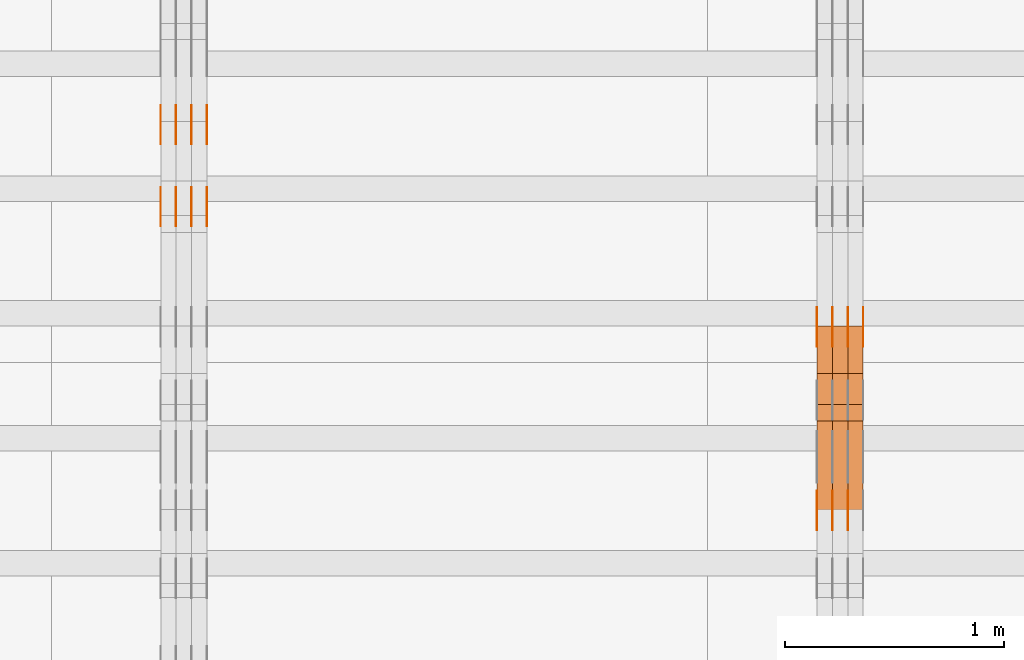
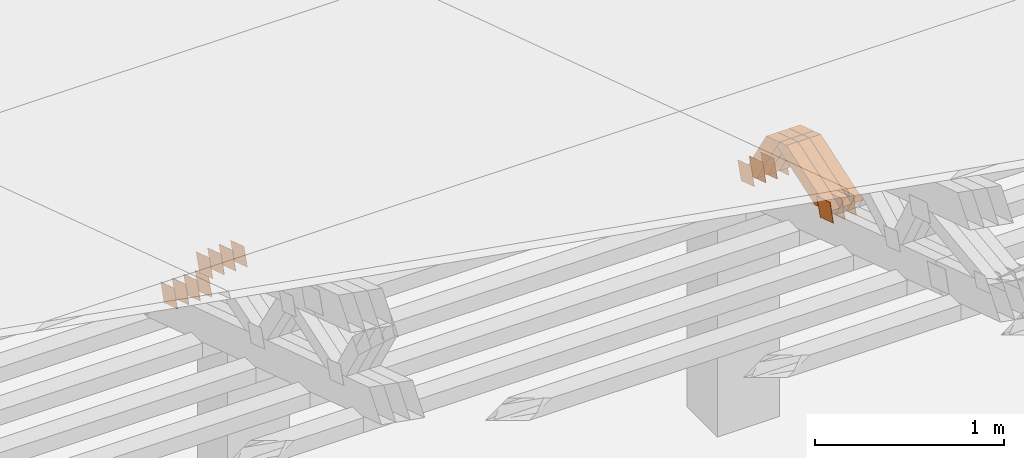
# One storey, part 197 of 385: 28 proxies.
"""IFC2X3 building model written with IfcOpenShell, lengths in millimetres."""

import ifcopenshell
import ifcopenshell.guid

model = None  # the IFC model being written
_history = None  # IfcOwnerHistory: only IFC2X3 demands one
_inside = {}  # id of a spatial element -> (the spatial element, [elements in it])
_under = {}  # id of a project, library or spatial element -> (it, [spatial elements below it])
_declared = {}  # id of a project -> (the project, [libraries it declares])
_typed = {}  # id of a type object -> (the type object, [elements of that type])
_made_of = {}  # id of a material, layer set ... -> (it, [elements and type objects made of it])


def new_model(schema):
    """Start an empty IFC model of exactly this schema.

    Asked for "IFC4X3", IfcOpenShell would pick the latest addendum, in which some entities
    have other attributes; the version numbers below select the first issue.
    IFC2X3 requires an IfcOwnerHistory on every rooted entity: one is made here for all.
    """
    global model, _history
    if schema == "IFC4X3":
        model = ifcopenshell.file(schema_version=(4, 3, 0, 0))
    else:
        model = ifcopenshell.file(schema=schema)
    _inside.clear()
    _under.clear()
    _declared.clear()
    _typed.clear()
    _made_of.clear()
    _history = None
    if model.schema == "IFC2X3":
        org = make("IfcOrganization", Name="unknown")
        user = make(
            "IfcPersonAndOrganization",
            ThePerson=make("IfcPerson", FamilyName="unknown"),
            TheOrganization=org,
        )
        app = make(
            "IfcApplication",
            ApplicationDeveloper=org,
            Version="unknown",
            ApplicationFullName="unknown",
            ApplicationIdentifier="unknown",
        )
        _history = make(
            "IfcOwnerHistory",
            OwningUser=user,
            OwningApplication=app,
            ChangeAction="ADDED",
            CreationDate=0,
        )
    return model


def make(cls, **values):
    """One entity of the class cls with the attributes given. An attribute that is None is left unset."""
    return model.create_entity(
        cls, **{name: value for name, value in values.items() if value is not None}
    )


def entity(cls, *values):
    """Any entity or typed value of the class cls, its attributes in the order of the schema. None: left unset."""
    e = model.create_entity(cls)
    for i, value in enumerate(values):
        if value is not None:
            e[i] = value
    return e


def rooted(cls, **values):
    """An entity with a GlobalId (a new one), such as an element, a storey or a relation."""
    return make(cls, GlobalId=ifcopenshell.guid.new(), OwnerHistory=_history, **values)


def si_unit(unit_type, name, prefix=None):
    """IfcSIUnit, for example si_unit("LENGTHUNIT", "METRE", prefix="MILLI")."""
    return make("IfcSIUnit", UnitType=unit_type, Prefix=prefix, Name=name)


def converted_unit(unit_type, name, factor, base, dimensions=None, offset=None):
    """IfcConversionBasedUnit, such as the inch: factor (a typed value) times the base unit."""
    return make(
        "IfcConversionBasedUnit"
        if offset is None
        else "IfcConversionBasedUnitWithOffset",
        ConversionOffset=offset,
        Dimensions=None
        if dimensions is None
        else entity("IfcDimensionalExponents", *dimensions),
        UnitType=unit_type,
        Name=name,
        ConversionFactor=make(
            "IfcMeasureWithUnit", ValueComponent=factor, UnitComponent=base
        ),
    )


def derived_unit(unit_type, elements):
    """IfcDerivedUnit: a product of units, each with its exponent."""
    return make(
        "IfcDerivedUnit",
        Elements=[
            make("IfcDerivedUnitElement", Unit=unit, Exponent=power)
            for unit, power in elements
        ],
        UnitType=unit_type,
    )


def assignment(units):
    """IfcUnitAssignment: the units of a project."""
    return None if units is None else make("IfcUnitAssignment", Units=units)


def point(xyz):
    """IfcCartesianPoint."""
    return None if xyz is None else make("IfcCartesianPoint", Coordinates=xyz)


def direction(xyz):
    """IfcDirection."""
    return None if xyz is None else make("IfcDirection", DirectionRatios=xyz)


def frame(location, z_axis=None, x_axis=None):
    """IfcAxis2Placement3D, a coordinate frame: its origin and axes. An axis left out is left unset."""
    return make(
        "IfcAxis2Placement3D",
        Location=point(location),
        Axis=direction(z_axis),
        RefDirection=direction(x_axis),
    )


def origin():
    """The frame at (0, 0, 0) with its axes left unset."""
    return frame((0.0, 0.0, 0.0))


def place(relative_to, where):
    """IfcLocalPlacement: puts the frame where relative to a parent placement (None: the world)."""
    return make(
        "IfcLocalPlacement", PlacementRelTo=relative_to, RelativePlacement=where
    )


def context(
    kind, dimensions, precision=None, world=None, true_north=None, identifier=None
):
    """IfcGeometricRepresentationContext, for example the 3D "Model" context."""
    return make(
        "IfcGeometricRepresentationContext",
        ContextIdentifier=identifier,
        ContextType=kind,
        CoordinateSpaceDimension=dimensions,
        Precision=precision,
        WorldCoordinateSystem=world,
        TrueNorth=true_north,
    )


def subcontext(parent, identifier, kind, view, scale=None):
    """IfcGeometricRepresentationSubContext, for example "Body" below "Model"."""
    return make(
        "IfcGeometricRepresentationSubContext",
        ContextIdentifier=identifier,
        ContextType=kind,
        ParentContext=parent,
        TargetScale=scale,
        TargetView=view,
    )


def project(units=None, contexts=None):
    """IfcProject with its units and contexts."""
    return rooted(
        "IfcProject",
        Name="project",
        RepresentationContexts=contexts,
        UnitsInContext=assignment(units),
    )


def spatial(cls, under=None, at=None, **own):
    """A site, building, storey or space (cls), placed at a placement, below another one or the project."""
    s = rooted(cls, ObjectPlacement=at, **own)
    if under is not None:
        _under.setdefault(under.id(), (under, []))[1].append(s)
    return s


def polyline(points):
    """IfcPolyline through the points."""
    return make("IfcPolyline", Points=[point(p) for p in points])


def outline(outer, holes=None, kind="AREA"):
    """IfcArbitraryClosedProfileDef: a profile drawn as a closed curve; with holes, ...WithVoids."""
    if holes is None:
        return make("IfcArbitraryClosedProfileDef", ProfileType=kind, OuterCurve=outer)
    return make(
        "IfcArbitraryProfileDefWithVoids",
        ProfileType=kind,
        OuterCurve=outer,
        InnerCurves=holes,
    )


def extrude(swept, where, along, depth):
    """IfcExtrudedAreaSolid: the profile swept, set in the frame where, extruded along a direction by depth."""
    return make(
        "IfcExtrudedAreaSolid",
        SweptArea=swept,
        Position=where,
        ExtrudedDirection=direction(along),
        Depth=depth,
    )


def shape(context_of_items, identifier, shape_type, items):
    """IfcShapeRepresentation: the items that make up one representation, for example the "Body"."""
    return make(
        "IfcShapeRepresentation",
        ContextOfItems=context_of_items,
        RepresentationIdentifier=identifier,
        RepresentationType=shape_type,
        Items=items,
    )


def source(mapping_origin, context_of_items, identifier, shape_type, items):
    """IfcRepresentationMap: a shape defined once, which mapped items show again and again."""
    return make(
        "IfcRepresentationMap",
        MappingOrigin=mapping_origin,
        MappedRepresentation=shape(context_of_items, identifier, shape_type, items),
    )


def transform(
    local_origin,
    x_axis=None,
    y_axis=None,
    z_axis=None,
    scale=None,
    scale2=None,
    scale3=None,
    uniform=True,
):
    """IfcCartesianTransformationOperator3D, or its non-uniform kind. x_axis, y_axis, z_axis: its Axis1, 2, 3."""
    if uniform:
        return make(
            "IfcCartesianTransformationOperator3D",
            Axis1=direction(x_axis),
            Axis2=direction(y_axis),
            LocalOrigin=point(local_origin),
            Scale=scale,
            Axis3=direction(z_axis),
        )
    return make(
        "IfcCartesianTransformationOperator3DnonUniform",
        Axis1=direction(x_axis),
        Axis2=direction(y_axis),
        LocalOrigin=point(local_origin),
        Scale=scale,
        Axis3=direction(z_axis),
        Scale2=scale2,
        Scale3=scale3,
    )


def mapped(mapping_source, mapping_target):
    """IfcMappedItem: shows the shape of a source again, moved by a transform."""
    return make(
        "IfcMappedItem", MappingSource=mapping_source, MappingTarget=mapping_target
    )


def material(Name=None, Category=None):
    """IfcMaterial."""
    return make("IfcMaterial", Name=Name, Category=Category)


def made_of(thing, what):
    """Note that an element or type object is made of a material, layer set ...; save() writes the relation."""
    if what is not None:
        _made_of.setdefault(what.id(), (what, []))[1].append(thing)
    return thing


def type_object(cls, material=None, **own):
    """A type object (cls), such as IfcWallType, which elements share."""
    return made_of(rooted(cls, **own), material)


def type_shapes(of_type, sources):
    """Give a type object the sources (RepresentationMaps) that its elements show as mapped items."""
    of_type.RepresentationMaps = sources


def element(
    cls,
    number,
    at=None,
    inside=None,
    cuts=None,
    type_object=None,
    material=None,
    context=None,
    identifier="Body",
    shape_type=None,
    held_by="IfcProductDefinitionShape",
    body=None,
    shapes=None,
    **own,
):
    """One element of the class cls, such as IfcWall. Its Tag is "e" and its number.

    at: its placement. inside: the storey or other place that contains it. cuts: it is an
    opening in that element (IfcRelVoidsElement). A single representation is given by context,
    identifier, shape_type and body (its items); several are given by shapes. held_by: the class
    of the entity that holds the representations. save() writes the other relations.
    """
    e = rooted(cls, Tag="e%d" % number, ObjectPlacement=at, **own)
    if body is not None:
        shapes = [shape(context, identifier, shape_type, body)]
    if shapes is not None:
        e.Representation = make(held_by, Representations=shapes)
    if inside is not None:
        _inside.setdefault(inside.id(), (inside, []))[1].append(e)
    if cuts is not None:
        rooted(
            "IfcRelVoidsElement", RelatingBuildingElement=cuts, RelatedOpeningElement=e
        )
    if type_object is not None:
        _typed.setdefault(type_object.id(), (type_object, []))[1].append(e)
    return made_of(e, material)


def aggregate(whole, parts):
    """IfcRelAggregates: a whole, such as a stair, and the parts it consists of."""
    return rooted("IfcRelAggregates", RelatingObject=whole, RelatedObjects=parts)


def save(model, path):
    """Write the relations noted so far, then the file.

    IfcRelAggregates (storeys below a building ...), IfcRelContainedInSpatialStructure (elements
    in a storey), IfcRelDefinesByType, IfcRelAssociatesMaterial and IfcRelDeclares: one each for
    every whole, place, type object, material and project.
    """
    for whole, parts in _under.values():
        aggregate(whole, parts)
    for where, things in _inside.values():
        rooted(
            "IfcRelContainedInSpatialStructure",
            RelatedElements=things,
            RelatingStructure=where,
        )
    for kind, things in _typed.values():
        rooted("IfcRelDefinesByType", RelatedObjects=things, RelatingType=kind)
    for what, things in _made_of.values():
        rooted("IfcRelAssociatesMaterial", RelatedObjects=things, RelatingMaterial=what)
    for by, libraries in _declared.values():
        rooted("IfcRelDeclares", RelatingContext=by, RelatedDefinitions=libraries)
    model.write(path)


model = new_model("IFC2X3")

# Units and contexts
model_context = context("Model", 3, precision=0.01, world=origin(), true_north=direction((6.12303176911189e-17, 1.0)))
body_context = subcontext(model_context, "Body", "Model", "MODEL_VIEW")
ifc_project = project(units=[si_unit("LENGTHUNIT", "METRE", prefix="MILLI"), si_unit("AREAUNIT", "SQUARE_METRE"), si_unit("VOLUMEUNIT", "CUBIC_METRE"), converted_unit("PLANEANGLEUNIT", "DEGREE", entity("IfcRatioMeasure", 0.0174532925199433), si_unit("PLANEANGLEUNIT", "RADIAN"), dimensions=[0, 0, 0, 0, 0, 0, 0]), si_unit("MASSUNIT", "GRAM", prefix="KILO"), derived_unit("MASSDENSITYUNIT", [(si_unit("MASSUNIT", "GRAM", prefix="KILO"), 1), (si_unit("LENGTHUNIT", "METRE"), -3)]), si_unit("TIMEUNIT", "SECOND"), si_unit("FREQUENCYUNIT", "HERTZ"), si_unit("THERMODYNAMICTEMPERATUREUNIT", "DEGREE_CELSIUS"), derived_unit("THERMALTRANSMITTANCEUNIT", [(si_unit("MASSUNIT", "GRAM", prefix="KILO"), 1), (si_unit("THERMODYNAMICTEMPERATUREUNIT", "KELVIN"), -1), (si_unit("TIMEUNIT", "SECOND"), -3)]), derived_unit("VOLUMETRICFLOWRATEUNIT", [(si_unit("LENGTHUNIT", "METRE"), 3), (si_unit("TIMEUNIT", "SECOND"), -1)]), si_unit("ELECTRICCURRENTUNIT", "AMPERE"), si_unit("ELECTRICVOLTAGEUNIT", "VOLT"), si_unit("POWERUNIT", "WATT"), si_unit("FORCEUNIT", "NEWTON", prefix="KILO"), si_unit("ILLUMINANCEUNIT", "LUX"), si_unit("LUMINOUSFLUXUNIT", "LUMEN"), si_unit("LUMINOUSINTENSITYUNIT", "CANDELA"), derived_unit("USERDEFINED", [(si_unit("MASSUNIT", "GRAM", prefix="KILO"), -1), (si_unit("LENGTHUNIT", "METRE"), -2), (si_unit("TIMEUNIT", "SECOND"), 3), (si_unit("LUMINOUSFLUXUNIT", "LUMEN"), 1)]), derived_unit("LINEARVELOCITYUNIT", [(si_unit("LENGTHUNIT", "METRE"), 1), (si_unit("TIMEUNIT", "SECOND"), -1)]), si_unit("PRESSUREUNIT", "PASCAL"), derived_unit("USERDEFINED", [(si_unit("LENGTHUNIT", "METRE"), -2), (si_unit("MASSUNIT", "GRAM", prefix="KILO"), 1), (si_unit("TIMEUNIT", "SECOND"), -2)])], contexts=[model_context])

# Site, building, storey
site_placement = place(None, origin())
site = spatial("IfcSite", under=ifc_project, at=site_placement, CompositionType="ELEMENT")
building_placement = place(site_placement, origin())
building = spatial("IfcBuilding", under=site, at=building_placement, CompositionType="ELEMENT")
storey_placement = place(building_placement, origin())
storey = spatial("IfcBuildingStorey", under=building, at=storey_placement, Name="Default", CompositionType="ELEMENT", Elevation=0.0)

# Proxies
ifc_material_1 = material(Name="IfcSurfaceStyle #203896")
building_element_proxy_type_1 = type_object("IfcBuildingElementProxyType", PredefinedType="NOTDEFINED", material=ifc_material_1)
shared_shape_1 = source(origin(), body_context, "Body", "SweptSolid", [
    extrude(outline(polyline([(-74.9998605591118, -59.9999264677598), (74.9998754286171, -59.9999264677598), (74.9998605591136, 59.9999264677598), (-74.9998754286189, 59.9999264677598), (-74.9998605591118, -59.9999264677598)])), frame((75.0000347664736, 60.0000016373434, 0.0), z_axis=(0.0, 0.0, 1.0), x_axis=(-1.0, 0.0, 0.0)), (0.0, 0.0, 1.0), 1.3),
])
type_shapes(building_element_proxy_type_1, [shared_shape_1])
proxy_1_placement = place(building_placement, frame((15316.3, 20117.0890328685, 2105.40814929196), z_axis=(-1.0, 0.0, 0.0), x_axis=(0.0, -0.951056516295124, 0.309016994375039)))
element("IfcBuildingElementProxy", 1, at=proxy_1_placement, inside=storey, type_object=building_element_proxy_type_1, material=ifc_material_1, context=body_context, shape_type="MappedRepresentation", body=[
    mapped(shared_shape_1, transform((0.0, 0.0, 0.0), scale=1.0)),
])
ifc_material_2 = material(Name="IfcSurfaceStyle #203839")
building_element_proxy_type_2 = type_object("IfcBuildingElementProxyType", PredefinedType="NOTDEFINED", material=ifc_material_2)
shared_shape_2 = source(origin(), body_context, "Body", "SweptSolid", [
    extrude(outline(polyline([(-74.9998605591118, -59.9999264677598), (74.9998754286171, -59.9999264677598), (74.9998605591136, 59.9999264677598), (-74.9998754286189, 59.9999264677598), (-74.9998605591118, -59.9999264677598)])), frame((75.0000347664736, 60.0000016373434, 0.0), z_axis=(0.0, 0.0, 1.0), x_axis=(-1.0, 0.0, 0.0)), (0.0, 0.0, 1.0), 1.29999999999999),
])
type_shapes(building_element_proxy_type_2, [shared_shape_2])
proxy_2_placement = place(building_placement, frame((15245.0, 20117.0890328685, 2105.40814929196), z_axis=(-1.0, 0.0, 0.0), x_axis=(0.0, -0.951056516295124, 0.309016994375039)))
element("IfcBuildingElementProxy", 2, at=proxy_2_placement, inside=storey, type_object=building_element_proxy_type_2, material=ifc_material_2, context=body_context, shape_type="MappedRepresentation", body=[
    mapped(shared_shape_2, transform((0.0, 0.0, 0.0), scale=1.0)),
])
ifc_material_3 = material(Name="IfcSurfaceStyle #203782")
building_element_proxy_type_3 = type_object("IfcBuildingElementProxyType", PredefinedType="NOTDEFINED", material=ifc_material_3)
shared_shape_3 = source(origin(), body_context, "Body", "SweptSolid", [
    extrude(outline(polyline([(-74.9998605591118, -59.9999264677598), (74.9998754286171, -59.9999264677598), (74.9998605591136, 59.9999264677598), (-74.9998754286189, 59.9999264677598), (-74.9998605591118, -59.9999264677598)])), frame((75.0000347664736, 60.0000016373434, 0.0), z_axis=(0.0, 0.0, 1.0), x_axis=(-1.0, 0.0, 0.0)), (0.0, 0.0, 1.0), 1.29999999999999),
])
type_shapes(building_element_proxy_type_3, [shared_shape_3])
proxy_3_placement = place(building_placement, frame((15246.3, 20117.0890328685, 2105.40814929196), z_axis=(-1.0, 0.0, 0.0), x_axis=(0.0, -0.951056516295124, 0.309016994375039)))
element("IfcBuildingElementProxy", 3, at=proxy_3_placement, inside=storey, type_object=building_element_proxy_type_3, material=ifc_material_3, context=body_context, shape_type="MappedRepresentation", body=[
    mapped(shared_shape_3, transform((0.0, 0.0, 0.0), scale=1.0)),
])
ifc_material_4 = material(Name="IfcSurfaceStyle #203725")
building_element_proxy_type_4 = type_object("IfcBuildingElementProxyType", PredefinedType="NOTDEFINED", material=ifc_material_4)
shared_shape_4 = source(origin(), body_context, "Body", "SweptSolid", [
    extrude(outline(polyline([(-74.9998605591118, -59.9999264677598), (74.9998754286171, -59.9999264677598), (74.9998605591136, 59.9999264677598), (-74.9998754286189, 59.9999264677598), (-74.9998605591118, -59.9999264677598)])), frame((75.0000347664736, 60.0000016373434, 0.0), z_axis=(0.0, 0.0, 1.0), x_axis=(-1.0, 0.0, 0.0)), (0.0, 0.0, 1.0), 1.29999999999999),
])
type_shapes(building_element_proxy_type_4, [shared_shape_4])
proxy_4_placement = place(building_placement, frame((15175.0, 20117.0890328685, 2105.40814929196), z_axis=(-1.0, 0.0, 0.0), x_axis=(0.0, -0.951056516295124, 0.309016994375039)))
element("IfcBuildingElementProxy", 4, at=proxy_4_placement, inside=storey, type_object=building_element_proxy_type_4, material=ifc_material_4, context=body_context, shape_type="MappedRepresentation", body=[
    mapped(shared_shape_4, transform((0.0, 0.0, 0.0), scale=1.0)),
])
ifc_material_5 = material(Name="IfcSurfaceStyle #203668")
building_element_proxy_type_5 = type_object("IfcBuildingElementProxyType", PredefinedType="NOTDEFINED", material=ifc_material_5)
shared_shape_5 = source(origin(), body_context, "Body", "SweptSolid", [
    extrude(outline(polyline([(-74.9998794200132, -59.999984515643), (74.9998565677174, -59.999984515643), (74.9998794200123, 59.999984515643), (-74.9998565677165, 59.999984515643), (-74.9998794200132, -59.999984515643)])), frame((75.0002235343086, 60.0000596852268, 0.0), z_axis=(0.0, 0.0, 1.0), x_axis=(-1.0, 0.0, 0.0)), (0.0, 0.0, 1.0), 1.3),
])
type_shapes(building_element_proxy_type_5, [shared_shape_5])
proxy_5_placement = place(building_placement, frame((15386.3, 20956.2317725846, 1832.75404405346), z_axis=(-1.0, 0.0, 0.0), x_axis=(0.0, -0.951056516295124, 0.309016994375039)))
element("IfcBuildingElementProxy", 5, at=proxy_5_placement, inside=storey, type_object=building_element_proxy_type_5, material=ifc_material_5, context=body_context, shape_type="MappedRepresentation", body=[
    mapped(shared_shape_5, transform((0.0, 0.0, 0.0), scale=1.0)),
])
ifc_material_6 = material(Name="IfcSurfaceStyle #203611")
building_element_proxy_type_6 = type_object("IfcBuildingElementProxyType", PredefinedType="NOTDEFINED", material=ifc_material_6)
shared_shape_6 = source(origin(), body_context, "Body", "SweptSolid", [
    extrude(outline(polyline([(-74.9998794200132, -59.999984515643), (74.9998565677174, -59.999984515643), (74.9998794200123, 59.999984515643), (-74.9998565677165, 59.999984515643), (-74.9998794200132, -59.999984515643)])), frame((75.0002235343086, 60.0000596852268, 0.0), z_axis=(0.0, 0.0, 1.0), x_axis=(-1.0, 0.0, 0.0)), (0.0, 0.0, 1.0), 1.3),
])
type_shapes(building_element_proxy_type_6, [shared_shape_6])
proxy_6_placement = place(building_placement, frame((15315.0, 20956.2317725846, 1832.75404405346), z_axis=(-1.0, 0.0, 0.0), x_axis=(0.0, -0.951056516295124, 0.309016994375039)))
element("IfcBuildingElementProxy", 6, at=proxy_6_placement, inside=storey, type_object=building_element_proxy_type_6, material=ifc_material_6, context=body_context, shape_type="MappedRepresentation", body=[
    mapped(shared_shape_6, transform((0.0, 0.0, 0.0), scale=1.0)),
])
ifc_material_7 = material(Name="IfcSurfaceStyle #203554")
building_element_proxy_type_7 = type_object("IfcBuildingElementProxyType", PredefinedType="NOTDEFINED", material=ifc_material_7)
shared_shape_7 = source(origin(), body_context, "Body", "SweptSolid", [
    extrude(outline(polyline([(-74.9998794200132, -59.999984515643), (74.9998565677174, -59.999984515643), (74.9998794200123, 59.999984515643), (-74.9998565677165, 59.999984515643), (-74.9998794200132, -59.999984515643)])), frame((75.0002235343086, 60.0000596852268, 0.0), z_axis=(0.0, 0.0, 1.0), x_axis=(-1.0, 0.0, 0.0)), (0.0, 0.0, 1.0), 1.3),
])
type_shapes(building_element_proxy_type_7, [shared_shape_7])
proxy_7_placement = place(building_placement, frame((15316.3, 20956.2317725846, 1832.75404405346), z_axis=(-1.0, 0.0, 0.0), x_axis=(0.0, -0.951056516295124, 0.309016994375039)))
element("IfcBuildingElementProxy", 7, at=proxy_7_placement, inside=storey, type_object=building_element_proxy_type_7, material=ifc_material_7, context=body_context, shape_type="MappedRepresentation", body=[
    mapped(shared_shape_7, transform((0.0, 0.0, 0.0), scale=1.0)),
])
ifc_material_8 = material(Name="IfcSurfaceStyle #203497")
building_element_proxy_type_8 = type_object("IfcBuildingElementProxyType", PredefinedType="NOTDEFINED", material=ifc_material_8)
shared_shape_8 = source(origin(), body_context, "Body", "SweptSolid", [
    extrude(outline(polyline([(-74.9998794200132, -59.999984515643), (74.9998565677174, -59.999984515643), (74.9998794200123, 59.999984515643), (-74.9998565677165, 59.999984515643), (-74.9998794200132, -59.999984515643)])), frame((75.0002235343086, 60.0000596852268, 0.0), z_axis=(0.0, 0.0, 1.0), x_axis=(-1.0, 0.0, 0.0)), (0.0, 0.0, 1.0), 1.29999999999999),
])
type_shapes(building_element_proxy_type_8, [shared_shape_8])
proxy_8_placement = place(building_placement, frame((15245.0, 20956.2317725846, 1832.75404405346), z_axis=(-1.0, 0.0, 0.0), x_axis=(0.0, -0.951056516295124, 0.309016994375039)))
element("IfcBuildingElementProxy", 8, at=proxy_8_placement, inside=storey, type_object=building_element_proxy_type_8, material=ifc_material_8, context=body_context, shape_type="MappedRepresentation", body=[
    mapped(shared_shape_8, transform((0.0, 0.0, 0.0), scale=1.0)),
])
ifc_material_9 = material(Name="IfcSurfaceStyle #203440")
building_element_proxy_type_9 = type_object("IfcBuildingElementProxyType", PredefinedType="NOTDEFINED", material=ifc_material_9)
shared_shape_9 = source(origin(), body_context, "Body", "SweptSolid", [
    extrude(outline(polyline([(-74.9998794200132, -59.999984515643), (74.9998565677174, -59.999984515643), (74.9998794200123, 59.999984515643), (-74.9998565677165, 59.999984515643), (-74.9998794200132, -59.999984515643)])), frame((75.0002235343086, 60.0000596852268, 0.0), z_axis=(0.0, 0.0, 1.0), x_axis=(-1.0, 0.0, 0.0)), (0.0, 0.0, 1.0), 1.29999999999999),
])
type_shapes(building_element_proxy_type_9, [shared_shape_9])
proxy_9_placement = place(building_placement, frame((15246.3, 20956.2317725846, 1832.75404405346), z_axis=(-1.0, 0.0, 0.0), x_axis=(0.0, -0.951056516295124, 0.309016994375039)))
element("IfcBuildingElementProxy", 9, at=proxy_9_placement, inside=storey, type_object=building_element_proxy_type_9, material=ifc_material_9, context=body_context, shape_type="MappedRepresentation", body=[
    mapped(shared_shape_9, transform((0.0, 0.0, 0.0), scale=1.0)),
])
ifc_material_10 = material(Name="IfcSurfaceStyle #203383")
building_element_proxy_type_10 = type_object("IfcBuildingElementProxyType", PredefinedType="NOTDEFINED", material=ifc_material_10)
shared_shape_10 = source(origin(), body_context, "Body", "SweptSolid", [
    extrude(outline(polyline([(-74.9998794200132, -59.999984515643), (74.9998565677174, -59.999984515643), (74.9998794200123, 59.999984515643), (-74.9998565677165, 59.999984515643), (-74.9998794200132, -59.999984515643)])), frame((75.0002235343086, 60.0000596852268, 0.0), z_axis=(0.0, 0.0, 1.0), x_axis=(-1.0, 0.0, 0.0)), (0.0, 0.0, 1.0), 1.29999999999999),
])
type_shapes(building_element_proxy_type_10, [shared_shape_10])
proxy_10_placement = place(building_placement, frame((15175.0, 20956.2317725846, 1832.75404405346), z_axis=(-1.0, 0.0, 0.0), x_axis=(0.0, -0.951056516295124, 0.309016994375039)))
element("IfcBuildingElementProxy", 10, at=proxy_10_placement, inside=storey, type_object=building_element_proxy_type_10, material=ifc_material_10, context=body_context, shape_type="MappedRepresentation", body=[
    mapped(shared_shape_10, transform((0.0, 0.0, 0.0), scale=1.0)),
])
ifc_material_11 = material(Name="IfcSurfaceStyle #186406")
building_element_proxy_type_11 = type_object("IfcBuildingElementProxyType", Name="T1-W26 186404", PredefinedType="NOTDEFINED", material=ifc_material_11)
shared_shape_11 = source(origin(), body_context, "Body", "SweptSolid", [
    extrude(outline(polyline([(-339.390941716546, -47.5001331548025), (137.738864791781, -47.5001331548025), (201.272298560955, 6.02772073885038e-05), (212.703852542003, 47.5001030161988), (-212.324074178193, 47.5001030161988), (-339.390941716546, -47.5001331548025)])), frame((212.703852542003, 47.5001030161988, 0.0), z_axis=(0.0, 0.0, 1.0), x_axis=(-1.0, 0.0, 0.0)), (0.0, 0.0, 1.0), 70.0),
])
type_shapes(building_element_proxy_type_11, [shared_shape_11])
proxy_11_placement = place(building_placement, frame((15385.0, 20576.541015625, 2286.80981445313), z_axis=(-1.0, 0.0, 0.0), x_axis=(0.0, -0.946743816465327, -0.321987804093053)))
element("IfcBuildingElementProxy", 11, at=proxy_11_placement, inside=storey, type_object=building_element_proxy_type_11, material=ifc_material_11, Name="T1-W26", context=body_context, shape_type="MappedRepresentation", body=[
    mapped(shared_shape_11, transform((0.0, 0.0, 0.0), scale=1.0)),
])
ifc_material_12 = material(Name="IfcSurfaceStyle #186340")
building_element_proxy_type_12 = type_object("IfcBuildingElementProxyType", Name="T1-W26 186338", PredefinedType="NOTDEFINED", material=ifc_material_12)
shared_shape_12 = source(origin(), body_context, "Body", "SweptSolid", [
    extrude(outline(polyline([(-339.390941716546, -47.5001331548025), (137.738864791781, -47.5001331548025), (201.272298560955, 6.02772073885038e-05), (212.703852542003, 47.5001030161988), (-212.324074178193, 47.5001030161988), (-339.390941716546, -47.5001331548025)])), frame((212.703852542003, 47.5001030161988, 0.0), z_axis=(0.0, 0.0, 1.0), x_axis=(-1.0, 0.0, 0.0)), (0.0, 0.0, 1.0), 70.0),
])
type_shapes(building_element_proxy_type_12, [shared_shape_12])
proxy_12_placement = place(building_placement, frame((15315.0, 20576.541015625, 2286.80981445313), z_axis=(-1.0, 0.0, 0.0), x_axis=(0.0, -0.946743816465327, -0.321987804093053)))
element("IfcBuildingElementProxy", 12, at=proxy_12_placement, inside=storey, type_object=building_element_proxy_type_12, material=ifc_material_12, Name="T1-W26", context=body_context, shape_type="MappedRepresentation", body=[
    mapped(shared_shape_12, transform((0.0, 0.0, 0.0), scale=1.0)),
])
ifc_material_13 = material(Name="IfcSurfaceStyle #186274")
building_element_proxy_type_13 = type_object("IfcBuildingElementProxyType", Name="T1-W26 186272", PredefinedType="NOTDEFINED", material=ifc_material_13)
shared_shape_13 = source(origin(), body_context, "Body", "SweptSolid", [
    extrude(outline(polyline([(-339.390941716546, -47.5001331548025), (137.738864791781, -47.5001331548025), (201.272298560955, 6.02772073885038e-05), (212.703852542003, 47.5001030161988), (-212.324074178193, 47.5001030161988), (-339.390941716546, -47.5001331548025)])), frame((212.703852542003, 47.5001030161988, 0.0), z_axis=(0.0, 0.0, 1.0), x_axis=(-1.0, 0.0, 0.0)), (0.0, 0.0, 1.0), 70.0),
])
type_shapes(building_element_proxy_type_13, [shared_shape_13])
proxy_13_placement = place(building_placement, frame((15245.0, 20576.541015625, 2286.80981445313), z_axis=(-1.0, 0.0, 0.0), x_axis=(0.0, -0.946743816465327, -0.321987804093053)))
element("IfcBuildingElementProxy", 13, at=proxy_13_placement, inside=storey, type_object=building_element_proxy_type_13, material=ifc_material_13, Name="T1-W26", context=body_context, shape_type="MappedRepresentation", body=[
    mapped(shared_shape_13, transform((0.0, 0.0, 0.0), scale=1.0)),
])
ifc_material_14 = material(Name="IfcSurfaceStyle #186010")
building_element_proxy_type_14 = type_object("IfcBuildingElementProxyType", Name="T1-W29 186008", PredefinedType="NOTDEFINED", material=ifc_material_14)
shared_shape_14 = source(origin(), body_context, "Body", "SweptSolid", [
    extrude(outline(polyline([(-202.325994317059, -47.5000867467013), (200.714255560873, -47.5000867467013), (187.834128885383, 0.000593513395139059), (130.590899902046, 47.4997899900038), (-316.813290031243, 47.4997899900038), (-202.325994317059, -47.5000867467013)])), frame((200.714255560873, 47.5001935424745, 0.0), z_axis=(0.0, 0.0, 1.0), x_axis=(-1.0, 0.0, 0.0)), (0.0, 0.0, 1.0), 70.0),
])
type_shapes(building_element_proxy_type_14, [shared_shape_14])
proxy_14_placement = place(building_placement, frame((15385.0, 20827.0771193222, 1890.72342063252), z_axis=(-1.0, 0.0, 0.0), x_axis=(0.0, -0.534567451138397, 0.845125813227473)))
element("IfcBuildingElementProxy", 14, at=proxy_14_placement, inside=storey, type_object=building_element_proxy_type_14, material=ifc_material_14, Name="T1-W29", context=body_context, shape_type="MappedRepresentation", body=[
    mapped(shared_shape_14, transform((0.0, 0.0, 0.0), scale=1.0)),
])
ifc_material_15 = material(Name="IfcSurfaceStyle #185944")
building_element_proxy_type_15 = type_object("IfcBuildingElementProxyType", Name="T1-W29 185942", PredefinedType="NOTDEFINED", material=ifc_material_15)
shared_shape_15 = source(origin(), body_context, "Body", "SweptSolid", [
    extrude(outline(polyline([(-202.325994317059, -47.5000867467013), (200.714255560873, -47.5000867467013), (187.834128885383, 0.000593513395139059), (130.590899902046, 47.4997899900038), (-316.813290031243, 47.4997899900038), (-202.325994317059, -47.5000867467013)])), frame((200.714255560873, 47.5001935424745, 0.0), z_axis=(0.0, 0.0, 1.0), x_axis=(-1.0, 0.0, 0.0)), (0.0, 0.0, 1.0), 70.0),
])
type_shapes(building_element_proxy_type_15, [shared_shape_15])
proxy_15_placement = place(building_placement, frame((15315.0, 20827.0771193222, 1890.72342063252), z_axis=(-1.0, 0.0, 0.0), x_axis=(0.0, -0.534567451138397, 0.845125813227473)))
element("IfcBuildingElementProxy", 15, at=proxy_15_placement, inside=storey, type_object=building_element_proxy_type_15, material=ifc_material_15, Name="T1-W29", context=body_context, shape_type="MappedRepresentation", body=[
    mapped(shared_shape_15, transform((0.0, 0.0, 0.0), scale=1.0)),
])
ifc_material_16 = material(Name="IfcSurfaceStyle #185878")
building_element_proxy_type_16 = type_object("IfcBuildingElementProxyType", Name="T1-W29 185876", PredefinedType="NOTDEFINED", material=ifc_material_16)
shared_shape_16 = source(origin(), body_context, "Body", "SweptSolid", [
    extrude(outline(polyline([(-202.325994317059, -47.5000867467013), (200.714255560873, -47.5000867467013), (187.834128885383, 0.000593513395139059), (130.590899902046, 47.4997899900038), (-316.813290031243, 47.4997899900038), (-202.325994317059, -47.5000867467013)])), frame((200.714255560873, 47.5001935424745, 0.0), z_axis=(0.0, 0.0, 1.0), x_axis=(-1.0, 0.0, 0.0)), (0.0, 0.0, 1.0), 70.0),
])
type_shapes(building_element_proxy_type_16, [shared_shape_16])
proxy_16_placement = place(building_placement, frame((15245.0, 20827.0771193222, 1890.72342063252), z_axis=(-1.0, 0.0, 0.0), x_axis=(0.0, -0.534567451138397, 0.845125813227473)))
element("IfcBuildingElementProxy", 16, at=proxy_16_placement, inside=storey, type_object=building_element_proxy_type_16, material=ifc_material_16, Name="T1-W29", context=body_context, shape_type="MappedRepresentation", body=[
    mapped(shared_shape_16, transform((0.0, 0.0, 0.0), scale=1.0)),
])
ifc_material_17 = material(Name="IfcSurfaceStyle #168894")
building_element_proxy_type_17 = type_object("IfcBuildingElementProxyType", PredefinedType="NOTDEFINED", material=ifc_material_17)
shared_shape_17 = source(origin(), body_context, "Body", "SweptSolid", [
    extrude(outline(polyline([(-75.0001116115454, -60.0000599592451), (75.0000887592496, -60.0000599592451), (75.0001116115454, 60.0000599592451), (-75.0000887592496, 60.0000599592451), (-75.0001116115454, -60.0000599592451)])), frame((75.0001116115454, 60.0000599592451, 0.0), z_axis=(0.0, 0.0, 1.0), x_axis=(-1.0, 0.0, 0.0)), (0.0, 0.0, 1.0), 1.3),
])
type_shapes(building_element_proxy_type_17, [shared_shape_17])
proxy_17_placement = place(building_placement, frame((12386.3, 21881.0815195707, 1532.2522473242), z_axis=(-1.0, 0.0, 0.0), x_axis=(0.0, -0.951056516295124, 0.309016994375039)))
element("IfcBuildingElementProxy", 17, at=proxy_17_placement, inside=storey, type_object=building_element_proxy_type_17, material=ifc_material_17, context=body_context, shape_type="MappedRepresentation", body=[
    mapped(shared_shape_17, transform((0.0, 0.0, 0.0), scale=1.0)),
])
ifc_material_18 = material(Name="IfcSurfaceStyle #168837")
building_element_proxy_type_18 = type_object("IfcBuildingElementProxyType", PredefinedType="NOTDEFINED", material=ifc_material_18)
shared_shape_18 = source(origin(), body_context, "Body", "SweptSolid", [
    extrude(outline(polyline([(-75.0001116115454, -60.0000599592451), (75.0000887592496, -60.0000599592451), (75.0001116115454, 60.0000599592451), (-75.0000887592496, 60.0000599592451), (-75.0001116115454, -60.0000599592451)])), frame((75.0001116115454, 60.0000599592451, 0.0), z_axis=(0.0, 0.0, 1.0), x_axis=(-1.0, 0.0, 0.0)), (0.0, 0.0, 1.0), 1.3),
])
type_shapes(building_element_proxy_type_18, [shared_shape_18])
proxy_18_placement = place(building_placement, frame((12315.0, 21881.0815195707, 1532.2522473242), z_axis=(-1.0, 0.0, 0.0), x_axis=(0.0, -0.951056516295124, 0.309016994375039)))
element("IfcBuildingElementProxy", 18, at=proxy_18_placement, inside=storey, type_object=building_element_proxy_type_18, material=ifc_material_18, context=body_context, shape_type="MappedRepresentation", body=[
    mapped(shared_shape_18, transform((0.0, 0.0, 0.0), scale=1.0)),
])
ifc_material_19 = material(Name="IfcSurfaceStyle #168780")
building_element_proxy_type_19 = type_object("IfcBuildingElementProxyType", PredefinedType="NOTDEFINED", material=ifc_material_19)
shared_shape_19 = source(origin(), body_context, "Body", "SweptSolid", [
    extrude(outline(polyline([(-75.0001116115454, -60.0000599592451), (75.0000887592496, -60.0000599592451), (75.0001116115454, 60.0000599592451), (-75.0000887592496, 60.0000599592451), (-75.0001116115454, -60.0000599592451)])), frame((75.0001116115454, 60.0000599592451, 0.0), z_axis=(0.0, 0.0, 1.0), x_axis=(-1.0, 0.0, 0.0)), (0.0, 0.0, 1.0), 1.3),
])
type_shapes(building_element_proxy_type_19, [shared_shape_19])
proxy_19_placement = place(building_placement, frame((12316.3, 21881.0815195707, 1532.2522473242), z_axis=(-1.0, 0.0, 0.0), x_axis=(0.0, -0.951056516295124, 0.309016994375039)))
element("IfcBuildingElementProxy", 19, at=proxy_19_placement, inside=storey, type_object=building_element_proxy_type_19, material=ifc_material_19, context=body_context, shape_type="MappedRepresentation", body=[
    mapped(shared_shape_19, transform((0.0, 0.0, 0.0), scale=1.0)),
])
ifc_material_20 = material(Name="IfcSurfaceStyle #168723")
building_element_proxy_type_20 = type_object("IfcBuildingElementProxyType", PredefinedType="NOTDEFINED", material=ifc_material_20)
shared_shape_20 = source(origin(), body_context, "Body", "SweptSolid", [
    extrude(outline(polyline([(-75.0001116115454, -60.0000599592451), (75.0000887592496, -60.0000599592451), (75.0001116115454, 60.0000599592451), (-75.0000887592496, 60.0000599592451), (-75.0001116115454, -60.0000599592451)])), frame((75.0001116115454, 60.0000599592451, 0.0), z_axis=(0.0, 0.0, 1.0), x_axis=(-1.0, 0.0, 0.0)), (0.0, 0.0, 1.0), 1.29999999999999),
])
type_shapes(building_element_proxy_type_20, [shared_shape_20])
proxy_20_placement = place(building_placement, frame((12245.0, 21881.0815195707, 1532.2522473242), z_axis=(-1.0, 0.0, 0.0), x_axis=(0.0, -0.951056516295124, 0.309016994375039)))
element("IfcBuildingElementProxy", 20, at=proxy_20_placement, inside=storey, type_object=building_element_proxy_type_20, material=ifc_material_20, context=body_context, shape_type="MappedRepresentation", body=[
    mapped(shared_shape_20, transform((0.0, 0.0, 0.0), scale=1.0)),
])
ifc_material_21 = material(Name="IfcSurfaceStyle #168666")
building_element_proxy_type_21 = type_object("IfcBuildingElementProxyType", PredefinedType="NOTDEFINED", material=ifc_material_21)
shared_shape_21 = source(origin(), body_context, "Body", "SweptSolid", [
    extrude(outline(polyline([(-75.0001116115454, -60.0000599592451), (75.0000887592496, -60.0000599592451), (75.0001116115454, 60.0000599592451), (-75.0000887592496, 60.0000599592451), (-75.0001116115454, -60.0000599592451)])), frame((75.0001116115454, 60.0000599592451, 0.0), z_axis=(0.0, 0.0, 1.0), x_axis=(-1.0, 0.0, 0.0)), (0.0, 0.0, 1.0), 1.29999999999999),
])
type_shapes(building_element_proxy_type_21, [shared_shape_21])
proxy_21_placement = place(building_placement, frame((12246.3, 21881.0815195707, 1532.2522473242), z_axis=(-1.0, 0.0, 0.0), x_axis=(0.0, -0.951056516295124, 0.309016994375039)))
element("IfcBuildingElementProxy", 21, at=proxy_21_placement, inside=storey, type_object=building_element_proxy_type_21, material=ifc_material_21, context=body_context, shape_type="MappedRepresentation", body=[
    mapped(shared_shape_21, transform((0.0, 0.0, 0.0), scale=1.0)),
])
ifc_material_22 = material(Name="IfcSurfaceStyle #168609")
building_element_proxy_type_22 = type_object("IfcBuildingElementProxyType", PredefinedType="NOTDEFINED", material=ifc_material_22)
shared_shape_22 = source(origin(), body_context, "Body", "SweptSolid", [
    extrude(outline(polyline([(-75.0001116115454, -60.0000599592451), (75.0000887592496, -60.0000599592451), (75.0001116115454, 60.0000599592451), (-75.0000887592496, 60.0000599592451), (-75.0001116115454, -60.0000599592451)])), frame((75.0001116115454, 60.0000599592451, 0.0), z_axis=(0.0, 0.0, 1.0), x_axis=(-1.0, 0.0, 0.0)), (0.0, 0.0, 1.0), 1.29999999999999),
])
type_shapes(building_element_proxy_type_22, [shared_shape_22])
proxy_22_placement = place(building_placement, frame((12175.0, 21881.0815195707, 1532.2522473242), z_axis=(-1.0, 0.0, 0.0), x_axis=(0.0, -0.951056516295124, 0.309016994375039)))
element("IfcBuildingElementProxy", 22, at=proxy_22_placement, inside=storey, type_object=building_element_proxy_type_22, material=ifc_material_22, context=body_context, shape_type="MappedRepresentation", body=[
    mapped(shared_shape_22, transform((0.0, 0.0, 0.0), scale=1.0)),
])
ifc_material_23 = material(Name="IfcSurfaceStyle #163422")
building_element_proxy_type_23 = type_object("IfcBuildingElementProxyType", PredefinedType="NOTDEFINED", material=ifc_material_23)
shared_shape_23 = source(origin(), body_context, "Body", "SweptSolid", [
    extrude(outline(polyline([(-74.9998794200064, -59.9999845156358), (74.9998565677224, -59.9999845156358), (74.9998794200064, 59.9999845156358), (-74.9998565677224, 59.9999845156358), (-74.9998794200064, -59.9999845156358)])), frame((74.9999765995044, 60.0000596852337, 0.0), z_axis=(0.0, 0.0, 1.0), x_axis=(-1.0, 0.0, 0.0)), (0.0, 0.0, 1.0), 1.3),
])
type_shapes(building_element_proxy_type_23, [shared_shape_23])
proxy_23_placement = place(building_placement, frame((12386.3, 21505.9776314857, 1954.5332951652), z_axis=(-1.0, 0.0, 0.0), x_axis=(0.0, -0.951056516295154, 0.309016994374948)))
element("IfcBuildingElementProxy", 23, at=proxy_23_placement, inside=storey, type_object=building_element_proxy_type_23, material=ifc_material_23, context=body_context, shape_type="MappedRepresentation", body=[
    mapped(shared_shape_23, transform((0.0, 0.0, 0.0), scale=1.0)),
])
ifc_material_24 = material(Name="IfcSurfaceStyle #163365")
building_element_proxy_type_24 = type_object("IfcBuildingElementProxyType", PredefinedType="NOTDEFINED", material=ifc_material_24)
shared_shape_24 = source(origin(), body_context, "Body", "SweptSolid", [
    extrude(outline(polyline([(-74.9998794200064, -59.9999845156358), (74.9998565677224, -59.9999845156358), (74.9998794200064, 59.9999845156358), (-74.9998565677224, 59.9999845156358), (-74.9998794200064, -59.9999845156358)])), frame((74.9999765995044, 60.0000596852337, 0.0), z_axis=(0.0, 0.0, 1.0), x_axis=(-1.0, 0.0, 0.0)), (0.0, 0.0, 1.0), 1.3),
])
type_shapes(building_element_proxy_type_24, [shared_shape_24])
proxy_24_placement = place(building_placement, frame((12315.0, 21505.9776314857, 1954.5332951652), z_axis=(-1.0, 0.0, 0.0), x_axis=(0.0, -0.951056516295154, 0.309016994374948)))
element("IfcBuildingElementProxy", 24, at=proxy_24_placement, inside=storey, type_object=building_element_proxy_type_24, material=ifc_material_24, context=body_context, shape_type="MappedRepresentation", body=[
    mapped(shared_shape_24, transform((0.0, 0.0, 0.0), scale=1.0)),
])
ifc_material_25 = material(Name="IfcSurfaceStyle #163308")
building_element_proxy_type_25 = type_object("IfcBuildingElementProxyType", PredefinedType="NOTDEFINED", material=ifc_material_25)
shared_shape_25 = source(origin(), body_context, "Body", "SweptSolid", [
    extrude(outline(polyline([(-74.9998794200064, -59.9999845156358), (74.9998565677224, -59.9999845156358), (74.9998794200064, 59.9999845156358), (-74.9998565677224, 59.9999845156358), (-74.9998794200064, -59.9999845156358)])), frame((74.9999765995044, 60.0000596852337, 0.0), z_axis=(0.0, 0.0, 1.0), x_axis=(-1.0, 0.0, 0.0)), (0.0, 0.0, 1.0), 1.3),
])
type_shapes(building_element_proxy_type_25, [shared_shape_25])
proxy_25_placement = place(building_placement, frame((12316.3, 21505.9776314857, 1954.5332951652), z_axis=(-1.0, 0.0, 0.0), x_axis=(0.0, -0.951056516295154, 0.309016994374948)))
element("IfcBuildingElementProxy", 25, at=proxy_25_placement, inside=storey, type_object=building_element_proxy_type_25, material=ifc_material_25, context=body_context, shape_type="MappedRepresentation", body=[
    mapped(shared_shape_25, transform((0.0, 0.0, 0.0), scale=1.0)),
])
ifc_material_26 = material(Name="IfcSurfaceStyle #163251")
building_element_proxy_type_26 = type_object("IfcBuildingElementProxyType", PredefinedType="NOTDEFINED", material=ifc_material_26)
shared_shape_26 = source(origin(), body_context, "Body", "SweptSolid", [
    extrude(outline(polyline([(-74.9998794200064, -59.9999845156358), (74.9998565677224, -59.9999845156358), (74.9998794200064, 59.9999845156358), (-74.9998565677224, 59.9999845156358), (-74.9998794200064, -59.9999845156358)])), frame((74.9999765995044, 60.0000596852337, 0.0), z_axis=(0.0, 0.0, 1.0), x_axis=(-1.0, 0.0, 0.0)), (0.0, 0.0, 1.0), 1.29999999999999),
])
type_shapes(building_element_proxy_type_26, [shared_shape_26])
proxy_26_placement = place(building_placement, frame((12245.0, 21505.9776314857, 1954.5332951652), z_axis=(-1.0, 0.0, 0.0), x_axis=(0.0, -0.951056516295154, 0.309016994374948)))
element("IfcBuildingElementProxy", 26, at=proxy_26_placement, inside=storey, type_object=building_element_proxy_type_26, material=ifc_material_26, context=body_context, shape_type="MappedRepresentation", body=[
    mapped(shared_shape_26, transform((0.0, 0.0, 0.0), scale=1.0)),
])
ifc_material_27 = material(Name="IfcSurfaceStyle #163194")
building_element_proxy_type_27 = type_object("IfcBuildingElementProxyType", PredefinedType="NOTDEFINED", material=ifc_material_27)
shared_shape_27 = source(origin(), body_context, "Body", "SweptSolid", [
    extrude(outline(polyline([(-74.9998794200064, -59.9999845156358), (74.9998565677224, -59.9999845156358), (74.9998794200064, 59.9999845156358), (-74.9998565677224, 59.9999845156358), (-74.9998794200064, -59.9999845156358)])), frame((74.9999765995044, 60.0000596852337, 0.0), z_axis=(0.0, 0.0, 1.0), x_axis=(-1.0, 0.0, 0.0)), (0.0, 0.0, 1.0), 1.29999999999999),
])
type_shapes(building_element_proxy_type_27, [shared_shape_27])
proxy_27_placement = place(building_placement, frame((12246.3, 21505.9776314857, 1954.5332951652), z_axis=(-1.0, 0.0, 0.0), x_axis=(0.0, -0.951056516295154, 0.309016994374948)))
element("IfcBuildingElementProxy", 27, at=proxy_27_placement, inside=storey, type_object=building_element_proxy_type_27, material=ifc_material_27, context=body_context, shape_type="MappedRepresentation", body=[
    mapped(shared_shape_27, transform((0.0, 0.0, 0.0), scale=1.0)),
])
ifc_material_28 = material(Name="IfcSurfaceStyle #163137")
building_element_proxy_type_28 = type_object("IfcBuildingElementProxyType", PredefinedType="NOTDEFINED", material=ifc_material_28)
shared_shape_28 = source(origin(), body_context, "Body", "SweptSolid", [
    extrude(outline(polyline([(-74.9998794200064, -59.9999845156358), (74.9998565677224, -59.9999845156358), (74.9998794200064, 59.9999845156358), (-74.9998565677224, 59.9999845156358), (-74.9998794200064, -59.9999845156358)])), frame((74.9999765995044, 60.0000596852337, 0.0), z_axis=(0.0, 0.0, 1.0), x_axis=(-1.0, 0.0, 0.0)), (0.0, 0.0, 1.0), 1.29999999999999),
])
type_shapes(building_element_proxy_type_28, [shared_shape_28])
proxy_28_placement = place(building_placement, frame((12175.0, 21505.9776314857, 1954.5332951652), z_axis=(-1.0, 0.0, 0.0), x_axis=(0.0, -0.951056516295154, 0.309016994374948)))
element("IfcBuildingElementProxy", 28, at=proxy_28_placement, inside=storey, type_object=building_element_proxy_type_28, material=ifc_material_28, context=body_context, shape_type="MappedRepresentation", body=[
    mapped(shared_shape_28, transform((0.0, 0.0, 0.0), scale=1.0)),
])

save(model, "model.ifc")
